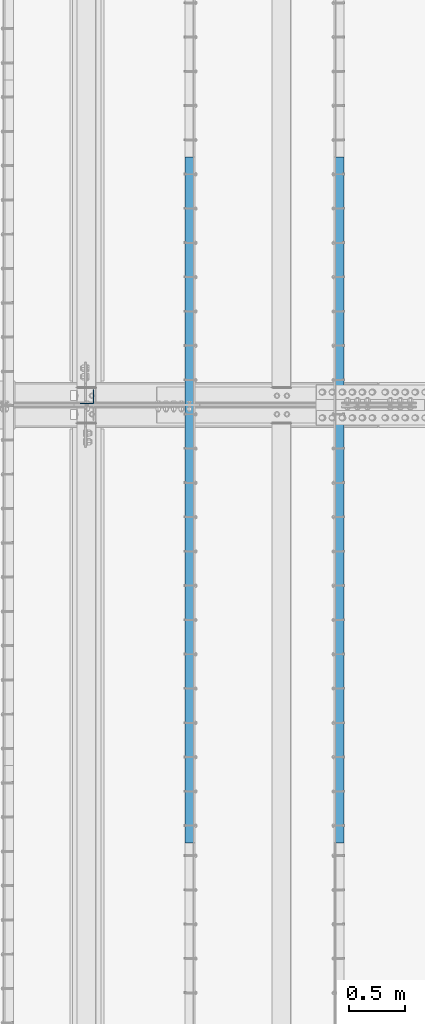
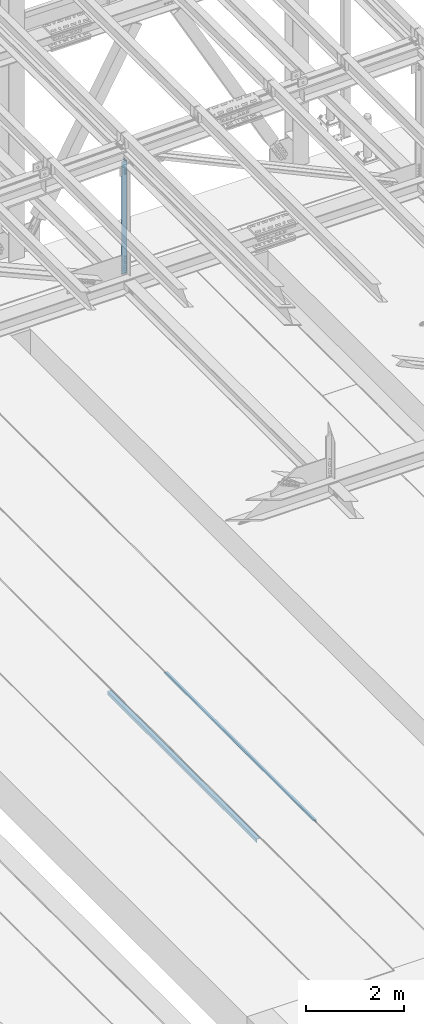
# One storey, part 1894 of 3843: 3 beams, 3 elements without a shape of their own.
"""IFC2X3 building model written with IfcOpenShell, lengths in millimetres."""

import ifcopenshell
import ifcopenshell.guid

model = None  # the IFC model being written
_history = None  # IfcOwnerHistory: only IFC2X3 demands one
_inside = {}  # id of a spatial element -> (the spatial element, [elements in it])
_under = {}  # id of a project, library or spatial element -> (it, [spatial elements below it])
_declared = {}  # id of a project -> (the project, [libraries it declares])
_typed = {}  # id of a type object -> (the type object, [elements of that type])
_made_of = {}  # id of a material, layer set ... -> (it, [elements and type objects made of it])


def new_model(schema):
    """Start an empty IFC model of exactly this schema.

    Asked for "IFC4X3", IfcOpenShell would pick the latest addendum, in which some entities
    have other attributes; the version numbers below select the first issue.
    IFC2X3 requires an IfcOwnerHistory on every rooted entity: one is made here for all.
    """
    global model, _history
    if schema == "IFC4X3":
        model = ifcopenshell.file(schema_version=(4, 3, 0, 0))
    else:
        model = ifcopenshell.file(schema=schema)
    _inside.clear()
    _under.clear()
    _declared.clear()
    _typed.clear()
    _made_of.clear()
    _history = None
    if model.schema == "IFC2X3":
        org = make("IfcOrganization", Name="unknown")
        user = make(
            "IfcPersonAndOrganization",
            ThePerson=make("IfcPerson", FamilyName="unknown"),
            TheOrganization=org,
        )
        app = make(
            "IfcApplication",
            ApplicationDeveloper=org,
            Version="unknown",
            ApplicationFullName="unknown",
            ApplicationIdentifier="unknown",
        )
        _history = make(
            "IfcOwnerHistory",
            OwningUser=user,
            OwningApplication=app,
            ChangeAction="ADDED",
            CreationDate=0,
        )
    return model


def make(cls, **values):
    """One entity of the class cls with the attributes given. An attribute that is None is left unset."""
    return model.create_entity(
        cls, **{name: value for name, value in values.items() if value is not None}
    )


def rooted(cls, **values):
    """An entity with a GlobalId (a new one), such as an element, a storey or a relation."""
    return make(cls, GlobalId=ifcopenshell.guid.new(), OwnerHistory=_history, **values)


def si_unit(unit_type, name, prefix=None):
    """IfcSIUnit, for example si_unit("LENGTHUNIT", "METRE", prefix="MILLI")."""
    return make("IfcSIUnit", UnitType=unit_type, Prefix=prefix, Name=name)


def assignment(units):
    """IfcUnitAssignment: the units of a project."""
    return None if units is None else make("IfcUnitAssignment", Units=units)


def point(xyz):
    """IfcCartesianPoint."""
    return None if xyz is None else make("IfcCartesianPoint", Coordinates=xyz)


def direction(xyz):
    """IfcDirection."""
    return None if xyz is None else make("IfcDirection", DirectionRatios=xyz)


def frame(location, z_axis=None, x_axis=None):
    """IfcAxis2Placement3D, a coordinate frame: its origin and axes. An axis left out is left unset."""
    return make(
        "IfcAxis2Placement3D",
        Location=point(location),
        Axis=direction(z_axis),
        RefDirection=direction(x_axis),
    )


def origin_with_axes():
    """The frame at (0, 0, 0) with the z axis (0, 0, 1) and the x axis (1, 0, 0) written out."""
    return frame((0.0, 0.0, 0.0), z_axis=(0.0, 0.0, 1.0), x_axis=(1.0, 0.0, 0.0))


def place(relative_to, where):
    """IfcLocalPlacement: puts the frame where relative to a parent placement (None: the world)."""
    return make(
        "IfcLocalPlacement", PlacementRelTo=relative_to, RelativePlacement=where
    )


def context(
    kind, dimensions, precision=None, world=None, true_north=None, identifier=None
):
    """IfcGeometricRepresentationContext, for example the 3D "Model" context."""
    return make(
        "IfcGeometricRepresentationContext",
        ContextIdentifier=identifier,
        ContextType=kind,
        CoordinateSpaceDimension=dimensions,
        Precision=precision,
        WorldCoordinateSystem=world,
        TrueNorth=true_north,
    )


def subcontext(parent, identifier, kind, view, scale=None):
    """IfcGeometricRepresentationSubContext, for example "Body" below "Model"."""
    return make(
        "IfcGeometricRepresentationSubContext",
        ContextIdentifier=identifier,
        ContextType=kind,
        ParentContext=parent,
        TargetScale=scale,
        TargetView=view,
    )


def project(units=None, contexts=None):
    """IfcProject with its units and contexts."""
    return rooted(
        "IfcProject",
        Name="project",
        RepresentationContexts=contexts,
        UnitsInContext=assignment(units),
    )


def spatial(cls, under=None, at=None, **own):
    """A site, building, storey or space (cls), placed at a placement, below another one or the project."""
    s = rooted(cls, ObjectPlacement=at, **own)
    if under is not None:
        _under.setdefault(under.id(), (under, []))[1].append(s)
    return s


def faces_of(points, faces, orient=None, outer=None):
    """IfcFace entities. A face is a list of loops; a loop is a list of indices into points, from 0.

    orient and outer hold one flag for each loop. By default every Orientation is true, the
    first loop of a face is its IfcFaceOuterBound and the others are IfcFaceBound.
    """
    made = []
    for i, loops in enumerate(faces):
        bounds = []
        for j, loop in enumerate(loops):
            is_outer = j == 0 if outer is None else outer[i][j]
            bounds.append(
                make(
                    "IfcFaceOuterBound" if is_outer else "IfcFaceBound",
                    Bound=make("IfcPolyLoop", Polygon=[points[k] for k in loop]),
                    Orientation=True if orient is None else orient[i][j],
                )
            )
        made.append(make("IfcFace", Bounds=bounds))
    return made


def faceted_brep(points, faces, orient=None, outer=None, voids=None):
    """IfcFacetedBrep: a solid bounded by flat faces; with voids (closed shells), ...WithVoids."""
    shared = [point(p) for p in points]
    hull = make("IfcClosedShell", CfsFaces=faces_of(shared, faces, orient, outer))
    if voids is None:
        return make("IfcFacetedBrep", Outer=hull)
    return make(
        "IfcFacetedBrepWithVoids",
        Outer=hull,
        Voids=[
            make(cls, CfsFaces=faces_of(shared, fs, o, b)) for cls, fs, o, b in voids
        ],
    )


def shape(context_of_items, identifier, shape_type, items):
    """IfcShapeRepresentation: the items that make up one representation, for example the "Body"."""
    return make(
        "IfcShapeRepresentation",
        ContextOfItems=context_of_items,
        RepresentationIdentifier=identifier,
        RepresentationType=shape_type,
        Items=items,
    )


def material(Name=None, Category=None):
    """IfcMaterial."""
    return make("IfcMaterial", Name=Name, Category=Category)


def made_of(thing, what):
    """Note that an element or type object is made of a material, layer set ...; save() writes the relation."""
    if what is not None:
        _made_of.setdefault(what.id(), (what, []))[1].append(thing)
    return thing


def type_object(cls, material=None, **own):
    """A type object (cls), such as IfcWallType, which elements share."""
    return made_of(rooted(cls, **own), material)


def element(
    cls,
    number,
    at=None,
    inside=None,
    cuts=None,
    type_object=None,
    material=None,
    context=None,
    identifier="Body",
    shape_type=None,
    held_by="IfcProductDefinitionShape",
    body=None,
    shapes=None,
    **own,
):
    """One element of the class cls, such as IfcWall. Its Tag is "e" and its number.

    at: its placement. inside: the storey or other place that contains it. cuts: it is an
    opening in that element (IfcRelVoidsElement). A single representation is given by context,
    identifier, shape_type and body (its items); several are given by shapes. held_by: the class
    of the entity that holds the representations. save() writes the other relations.
    """
    e = rooted(cls, Tag="e%d" % number, ObjectPlacement=at, **own)
    if body is not None:
        shapes = [shape(context, identifier, shape_type, body)]
    if shapes is not None:
        e.Representation = make(held_by, Representations=shapes)
    if inside is not None:
        _inside.setdefault(inside.id(), (inside, []))[1].append(e)
    if cuts is not None:
        rooted(
            "IfcRelVoidsElement", RelatingBuildingElement=cuts, RelatedOpeningElement=e
        )
    if type_object is not None:
        _typed.setdefault(type_object.id(), (type_object, []))[1].append(e)
    return made_of(e, material)


def aggregate(whole, parts):
    """IfcRelAggregates: a whole, such as a stair, and the parts it consists of."""
    return rooted("IfcRelAggregates", RelatingObject=whole, RelatedObjects=parts)


def save(model, path):
    """Write the relations noted so far, then the file.

    IfcRelAggregates (storeys below a building ...), IfcRelContainedInSpatialStructure (elements
    in a storey), IfcRelDefinesByType, IfcRelAssociatesMaterial and IfcRelDeclares: one each for
    every whole, place, type object, material and project.
    """
    for whole, parts in _under.values():
        aggregate(whole, parts)
    for where, things in _inside.values():
        rooted(
            "IfcRelContainedInSpatialStructure",
            RelatedElements=things,
            RelatingStructure=where,
        )
    for kind, things in _typed.values():
        rooted("IfcRelDefinesByType", RelatedObjects=things, RelatingType=kind)
    for what, things in _made_of.values():
        rooted("IfcRelAssociatesMaterial", RelatedObjects=things, RelatingMaterial=what)
    for by, libraries in _declared.values():
        rooted("IfcRelDeclares", RelatingContext=by, RelatedDefinitions=libraries)
    model.write(path)


model = new_model("IFC2X3")

# Units and contexts
model_context = context("Model", 3, precision=1e-05, world=origin_with_axes())
body_context = subcontext(model_context, "Body", "Model", "MODEL_VIEW")
ifc_project = project(units=[si_unit("LENGTHUNIT", "METRE", prefix="MILLI"), si_unit("AREAUNIT", "SQUARE_METRE"), si_unit("VOLUMEUNIT", "CUBIC_METRE"), si_unit("MASSUNIT", "GRAM", prefix="KILO"), si_unit("TIMEUNIT", "SECOND"), si_unit("PLANEANGLEUNIT", "RADIAN"), si_unit("SOLIDANGLEUNIT", "STERADIAN"), si_unit("THERMODYNAMICTEMPERATUREUNIT", "DEGREE_CELSIUS"), si_unit("LUMINOUSINTENSITYUNIT", "LUMEN")], contexts=[model_context])

# Site, building, storey
site_placement = place(None, origin_with_axes())
site = spatial("IfcSite", under=ifc_project, at=site_placement, CompositionType="ELEMENT")
building_placement = place(site_placement, origin_with_axes())
building = spatial("IfcBuilding", under=site, at=building_placement, Name="Undefined", CompositionType="ELEMENT")
storey_placement = place(building_placement, origin_with_axes())
storey = spatial("IfcBuildingStorey", under=building, at=storey_placement, Name="Undefined", CompositionType="ELEMENT", Elevation=0.0)

# Assembly, beam
assembly_1_placement = place(storey_placement, origin_with_axes())
assembly_1 = element("IfcElementAssembly", 1, at=assembly_1_placement, inside=storey, Name="EMBED_ANGLE", AssemblyPlace="NOTDEFINED", PredefinedType="RIGID_FRAME")
ifc_material_1 = material(Name="STEEL/A36")
beam_type_1 = type_object("IfcBeamType", Name="L3-1/2X3-1/2X5/16", PredefinedType="NOTDEFINED")
beam_1_placement = place(assembly_1_placement, frame((51238.9754423828, 71735.822703125, 30410.15), z_axis=(0.0, 0.0, -1.0), x_axis=(0.0, 1.0, 0.0)))
beam_1 = element("IfcBeam", 2, at=beam_1_placement, type_object=beam_type_1, material=ifc_material_1, Name="EMBED_ANGLE", ObjectType="L3-1/2X3-1/2X5/16", context=body_context, shape_type="Brep", body=[
    faceted_brep([(-3.63797880709171e-12, 44.4499999999971, -44.4500000000007), (-3.63797880709171e-12, 44.4499999999971, 44.4500000000007), (6096.0, 44.4499999999971, 44.4500000000007), (6096.0, 44.4499999999971, -44.4500000000007), (-3.63797880709171e-12, 36.5124999999971, 44.4500000000007), (6096.0, 36.5124999999971, 44.4500000000007), (-3.63797880709171e-12, 36.5124999999971, -36.5125000000007), (6096.0, 36.5124999999971, -36.5125000000007), (3.63797880709171e-12, -44.4499999999971, -36.5125000000007), (6096.0, -44.4499999999971, -36.5125000000007), (3.63797880709171e-12, -44.4499999999971, -44.4500000000007), (6096.0, -44.4499999999971, -44.4500000000007)], [[[0, 1, 2, 3]], [[1, 4, 5, 2]], [[4, 6, 7, 5]], [[6, 8, 9, 7]], [[8, 10, 11, 9]], [[10, 0, 3, 11]], [[5, 7, 9, 11, 3, 2]], [[10, 8, 6, 4, 1, 0]]]),
])
aggregate(assembly_1, [beam_1])

assembly_2_placement = place(storey_placement, origin_with_axes())
assembly_2 = element("IfcElementAssembly", 3, at=assembly_2_placement, inside=storey, Name="EMBED_ANGLE", AssemblyPlace="NOTDEFINED", PredefinedType="RIGID_FRAME")
beam_2_placement = place(assembly_2_placement, frame((49911.7620576172, 77831.822703125, 30410.15), z_axis=(0.0, 0.0, -1.0), x_axis=(0.0, -1.0, 0.0)))
beam_2 = element("IfcBeam", 4, at=beam_2_placement, type_object=beam_type_1, material=ifc_material_1, Name="EMBED_ANGLE", ObjectType="L3-1/2X3-1/2X5/16", context=body_context, shape_type="Brep", body=[
    faceted_brep([(-3.63797880709171e-12, 44.4499999999971, -44.4500000000007), (-3.63797880709171e-12, 44.4499999999971, 44.4500000000007), (6096.0, 44.4499999999971, 44.4500000000007), (6096.0, 44.4499999999971, -44.4500000000007), (-3.63797880709171e-12, 36.5124999999971, 44.4500000000007), (6096.0, 36.5124999999971, 44.4500000000007), (-3.63797880709171e-12, 36.5124999999971, -36.5125000000007), (6096.0, 36.5124999999971, -36.5125000000007), (3.63797880709171e-12, -44.4499999999971, -36.5125000000007), (6096.0, -44.4499999999971, -36.5125000000007), (3.63797880709171e-12, -44.4499999999971, -44.4500000000007), (6096.0, -44.4499999999971, -44.4500000000007)], [[[0, 1, 2, 3]], [[1, 4, 5, 2]], [[4, 6, 7, 5]], [[6, 8, 9, 7]], [[8, 10, 11, 9]], [[10, 0, 3, 11]], [[5, 7, 9, 11, 3, 2]], [[10, 8, 6, 4, 1, 0]]]),
])
aggregate(assembly_2, [beam_2])

assembly_3_placement = place(storey_placement, origin_with_axes())
assembly_3 = element("IfcElementAssembly", 5, at=assembly_3_placement, inside=storey, Name="ANGLE", AssemblyPlace="NOTDEFINED", PredefinedType="RIGID_FRAME")
ifc_material_2 = material(Name="STEEL/A572-50")
beam_type_2 = type_object("IfcBeamType", Name="L5X5X3/8", PredefinedType="NOTDEFINED")
beam_3_placement = place(assembly_3_placement, frame((48996.6, 75701.525, 45536.1452598678), z_axis=(-1.0, 0.0, 0.0), x_axis=(0.0, 0.0, -1.0)))
beam_3 = element("IfcBeam", 6, at=beam_3_placement, type_object=beam_type_2, material=ifc_material_2, Name="ANGLE", ObjectType="L5X5X3/8", context=body_context, shape_type="Brep", body=[
    faceted_brep([(224.247048074336, 63.5, -63.5), (224.247048074336, 63.5, 63.5), (3028.15339394045, 63.5, 63.5), (3028.15339394045, 63.5, -63.5), (224.247048074336, 53.9750000000058, 63.5), (3028.15339394045, 53.9750000000058, 63.5), (224.247048074336, 53.9750000000058, -53.9749999999985), (3028.15339394045, 53.9750000000058, -53.9749999999985), (224.247048074336, -63.5, -53.9749999999985), (3028.15339394045, -63.5, -53.9749999999985), (224.247048074336, -63.5, -63.5), (3028.15339394045, -63.5, -63.5)], [[[0, 1, 2, 3]], [[1, 4, 5, 2]], [[4, 6, 7, 5]], [[6, 8, 9, 7]], [[8, 10, 11, 9]], [[10, 0, 3, 11]], [[5, 7, 9, 11, 3, 2]], [[10, 8, 6, 4, 1, 0]]]),
])
aggregate(assembly_3, [beam_3])

save(model, "model.ifc")
